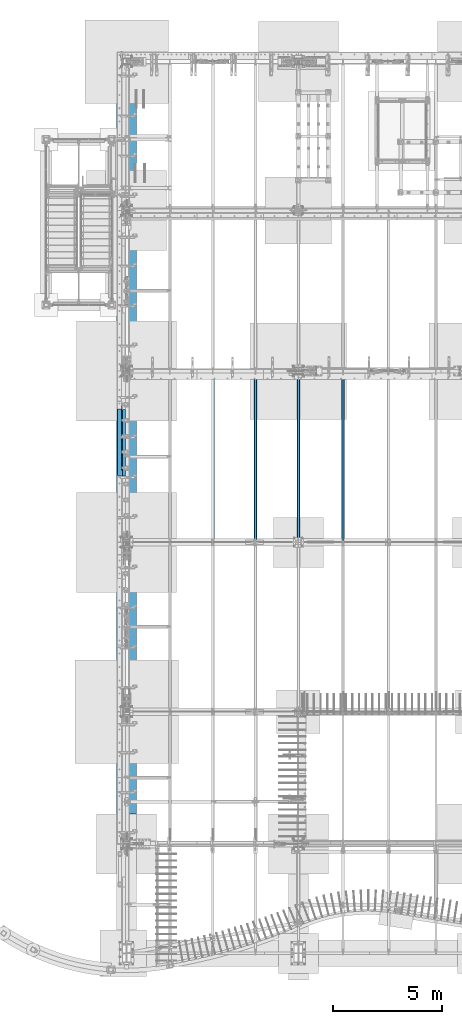
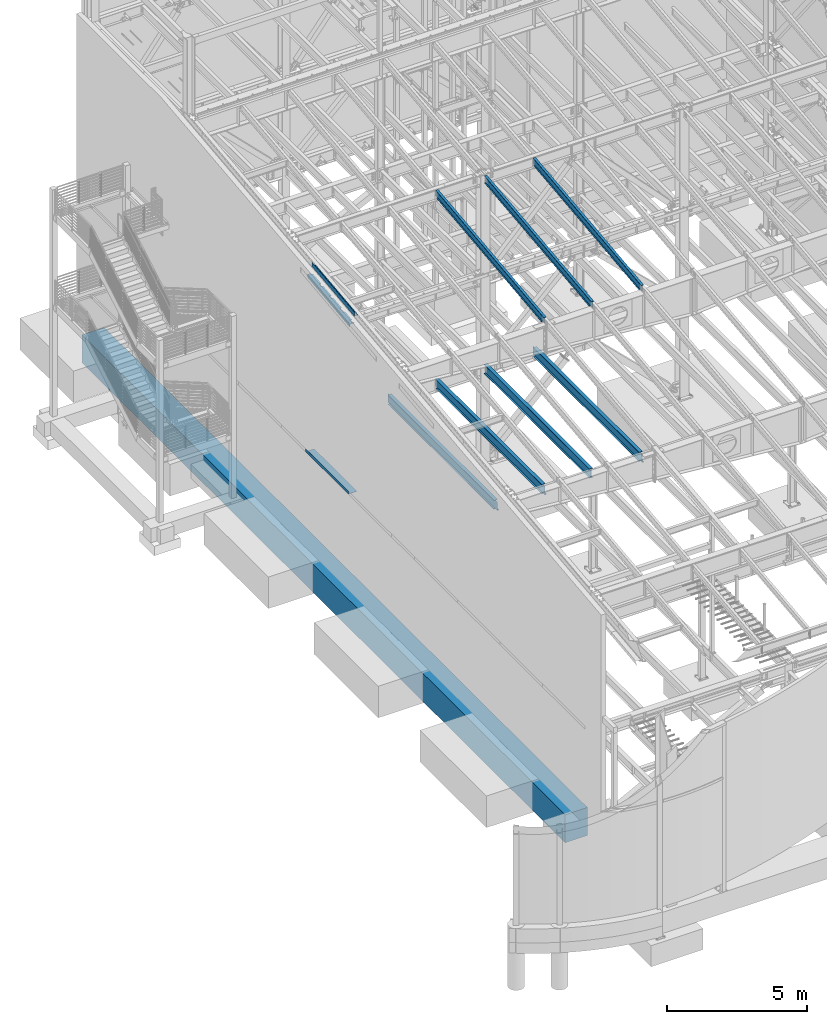
# One storey, part 727 of 1179: 11 beams, 10 elements without a shape of their own.
"""IFC2X3 building model written with IfcOpenShell, lengths in millimetres."""

from ifc_helpers import new_model, si_unit, frame, origin_with_axes, place, context, subcontext, project, spatial, faceted_brep, material, type_object, element, aggregate, save


model = new_model("IFC2X3")

# Units and contexts
model_context = context("Model", 3, precision=1e-05, world=origin_with_axes())
body_context = subcontext(model_context, "Body", "Model", "MODEL_VIEW")
ifc_project = project(units=[si_unit("LENGTHUNIT", "METRE", prefix="MILLI"), si_unit("AREAUNIT", "SQUARE_METRE"), si_unit("VOLUMEUNIT", "CUBIC_METRE"), si_unit("MASSUNIT", "GRAM", prefix="KILO"), si_unit("TIMEUNIT", "SECOND"), si_unit("PLANEANGLEUNIT", "RADIAN"), si_unit("SOLIDANGLEUNIT", "STERADIAN"), si_unit("THERMODYNAMICTEMPERATUREUNIT", "DEGREE_CELSIUS"), si_unit("LUMINOUSINTENSITYUNIT", "LUMEN")], contexts=[model_context])

# Site, building, storey
site_placement = place(None, origin_with_axes())
site = spatial("IfcSite", under=ifc_project, at=site_placement, CompositionType="ELEMENT")
building_placement = place(site_placement, origin_with_axes())
building = spatial("IfcBuilding", under=site, at=building_placement, Name="Undefined", CompositionType="ELEMENT")
storey_placement = place(building_placement, origin_with_axes())
storey = spatial("IfcBuildingStorey", under=building, at=storey_placement, Name="Undefined", CompositionType="ELEMENT", Elevation=0.0)

# Assembly, beam
assembly_1_placement = place(storey_placement, origin_with_axes())
assembly_1 = element("IfcElementAssembly", 1, at=assembly_1_placement, inside=storey, Name="BEAM", AssemblyPlace="NOTDEFINED", PredefinedType="RIGID_FRAME")
ifc_material_1 = material(Name="STEEL/A992")
beam_type_1 = type_object("IfcBeamType", Name="W16X31", PredefinedType="NOTDEFINED")
beam_1_placement = place(assembly_1_placement, frame((10325.1001686096, 19223.0375, 3900.4875), z_axis=(0.0, 0.0, 1.0), x_axis=(0.0, 1.0, 0.0)))
beam_1 = element("IfcBeam", 2, at=beam_1_placement, type_object=beam_type_1, material=ifc_material_1, Name="BEAM", ObjectType="W16X31", context=body_context, shape_type="Brep", body=[
    faceted_brep([(118.268749999999, -3.17499999999927, 169.862499809266), (118.268749999999, 3.17497767405257, 169.862499809266), (23.0187500000029, 3.17499999999927, 169.8625), (23.0187500000029, -3.17499999999927, 169.8625), (123.128829708781, -3.17499999999927, 170.829229922588), (123.128829708781, 3.17496867166847, 170.829229922588), (127.249006176935, -3.17499999999927, 173.582243823066), (127.249006176935, 3.17496689914333, 173.582243823066), (130.002020077412, -3.17499999999927, 177.70242029122), (130.002020077412, 3.17496424637102, 177.70242029122), (130.96875, -3.17499999999927, 182.562499809265), (130.96875, 3.17496111721084, 182.562499809265), (130.96875, -69.8500000000004, 201.6125), (130.96875, 69.8500000000004, 201.6125), (130.96875, 69.8500000000004, 190.5), (130.96875, 3.17499999999927, 190.5), (130.96875, -3.17499999999927, 190.5), (130.96875, -69.8500000000004, 190.5), (7651.75, 3.17499999999927, -190.5), (7651.75, 69.8500000000004, -190.5), (150.018750000003, 69.8500000000004, -190.5), (150.018749999999, 3.17549991607484, -190.5), (23.0187500000029, -3.17499999999927, -190.5), (23.0187500000029, -69.8500000000004, -190.5), (7807.325, -69.8500000000004, -190.5), (7807.325, -3.17499999999927, -190.5), (23.0187500000029, -69.8500000000004, -201.6125), (7807.325, -69.8500000000004, -201.6125), (7651.75, 69.8500000000004, -201.6125), (7651.75, 3.17549991607666, -201.6125), (7807.325, 3.17549991607666, -201.6125), (23.0187500000029, 3.17549991607484, -201.6125), (150.018749999999, 3.17549991607484, -201.6125), (150.018750000003, 69.8500000000004, -201.6125), (23.0187500000029, 3.17499999999927, -190.5), (7807.325, 3.17499999999927, -190.5), (7807.325, 3.17499999999927, 163.512499999999), (7807.325, -3.17499999999927, 163.512499999999), (7664.44999980926, 3.17499999999927, 163.512499999999), (7664.44999980926, -3.17499999999927, 163.512499999999), (7659.58992029121, 3.17499999999927, 164.479229922587), (7659.58992029121, -3.17499999999927, 164.479229922587), (7655.46974382306, 3.17499999999927, 167.232243823065), (7655.46974382306, -3.17499999999927, 167.232243823065), (7652.71672992258, 3.17499999999927, 171.352420291219), (7652.71672992258, -3.17499999999927, 171.352420291219), (7651.74999999999, 3.17499999999927, 176.212499809265), (7651.74999999999, -3.17499999999927, 176.212499809265), (7651.74999999999, -69.8500000000004, 201.6125), (7651.74999999999, -69.8500000000004, 190.5), (7651.74999999999, -3.17499999999927, 190.5), (7651.74999999999, 3.17499999999927, 190.5), (7651.74999999999, 69.8500000000004, 190.5), (7651.74999999999, 69.8500000000004, 201.6125)], [[[0, 1, 2, 3]], [[4, 5, 1, 0]], [[6, 7, 5, 4]], [[8, 9, 7, 6]], [[10, 11, 9, 8]], [[12, 13, 14, 15, 11, 10, 16, 17]], [[18, 19, 20, 21]], [[22, 23, 24, 25]], [[23, 26, 27, 24]], [[28, 29, 30, 27, 26, 31, 32, 33]], [[21, 32, 31, 34]], [[20, 33, 32, 21]], [[19, 28, 33, 20]], [[18, 29, 28, 19]], [[35, 30, 29, 18]], [[25, 24, 27, 30, 35, 36, 37]], [[37, 36, 38, 39]], [[39, 38, 40, 41]], [[41, 40, 42, 43]], [[43, 42, 44, 45]], [[45, 44, 46, 47]], [[48, 49, 50, 47, 46, 51, 52, 53]], [[49, 48, 12, 17]], [[50, 49, 17, 16]], [[8, 6, 4, 0, 3, 22, 25, 37, 39, 41, 43, 45, 47, 50, 16, 10]], [[34, 31, 26, 23, 22, 3, 2]], [[51, 46, 44, 42, 40, 38, 36, 35, 18, 21, 34, 2, 1, 5, 7, 9, 11, 15]], [[52, 51, 15, 14]], [[53, 52, 14, 13]], [[48, 53, 13, 12]]]),
])
aggregate(assembly_1, [beam_1])

assembly_2_placement = place(storey_placement, origin_with_axes())
assembly_2 = element("IfcElementAssembly", 3, at=assembly_2_placement, inside=storey, Name="BEAM", AssemblyPlace="NOTDEFINED", PredefinedType="RIGID_FRAME")
beam_2_placement = place(assembly_2_placement, frame((8280.4, 19227.8, 3900.4875), z_axis=(0.0, 0.0, 1.0), x_axis=(0.0, 1.0, 0.0)))
beam_2 = element("IfcBeam", 4, at=beam_2_placement, type_object=beam_type_1, material=ifc_material_1, Name="BEAM", ObjectType="W16X31", context=body_context, shape_type="Brep", body=[
    faceted_brep([(114.299999999999, -69.8500000000004, -201.6125), (114.299999999999, 69.8500000000004, -201.6125), (7627.9375, 69.8500000000004, -201.6125), (7627.9375, -69.8500000000004, -201.6125), (114.299999999999, -69.8500000000004, -190.5), (114.299999999999, -3.17499999999927, -190.5), (114.299999999999, -3.17499999999927, 190.5), (114.299999999999, -69.8500000000004, 190.5), (114.299999999999, -69.8500000000004, 201.6125), (114.299999999999, 69.8500000000004, 201.6125), (114.299999999999, 69.8500000000004, 190.5), (114.299999999999, 3.17499999999927, 190.5), (114.299999999999, 3.17499999999927, 164.25250072541), (114.299999999999, 3.17499999999927, -142.0275032968), (114.299999999999, 3.17499999999927, -190.5), (114.299999999999, 69.8500000000004, -190.5), (7627.9375, -69.8500000000004, -190.5), (7627.9375, -3.17499999999927, -190.5), (7627.9375, -3.17499999999927, 190.5), (7627.9375, -69.8500000000004, 190.5), (7627.9375, -69.8500000000004, 201.6125), (7627.9375, 69.8500000000004, 201.6125), (7627.9375, 69.8500000000004, 190.5), (7627.9375, 3.17499999999927, 190.5), (7627.9375, 3.17499999999927, -190.5), (7627.9375, 69.8500000000004, -190.5)], [[[0, 1, 2, 3]], [[0, 4, 5, 6, 7, 8, 9, 10, 11, 12, 13, 14, 15, 1]], [[5, 4, 16, 17]], [[6, 5, 17, 18]], [[7, 6, 18, 19]], [[8, 7, 19, 20]], [[9, 8, 20, 21]], [[10, 9, 21, 22]], [[11, 10, 22, 23]], [[14, 13, 12, 11, 23, 24]], [[15, 14, 24, 25]], [[1, 15, 25, 2]], [[24, 23, 22, 21, 20, 19, 18, 17, 16, 3, 2, 25]], [[4, 0, 3, 16]]]),
])
aggregate(assembly_2, [beam_2])

assembly_3_placement = place(storey_placement, origin_with_axes())
assembly_3 = element("IfcElementAssembly", 5, at=assembly_3_placement, inside=storey, Name="BEAM", AssemblyPlace="NOTDEFINED", PredefinedType="RIGID_FRAME")
beam_3_placement = place(assembly_3_placement, frame((6324.59996643066, 19223.0375, 3900.4875), z_axis=(0.0, 0.0, 1.0), x_axis=(0.0, 1.0, 0.0)))
beam_3 = element("IfcBeam", 6, at=beam_3_placement, type_object=beam_type_1, material=ifc_material_1, Name="BEAM", ObjectType="W16X31", context=body_context, shape_type="Brep", body=[
    faceted_brep([(118.268749999999, -3.17499999999927, 169.862499809266), (118.268749999999, 3.17497767405257, 169.862499809266), (23.0187500000029, 3.17499999999927, 169.8625), (23.0187500000029, -3.17499999999927, 169.8625), (123.128829708781, -3.17499999999927, 170.829229922588), (123.128829708781, 3.17496867166847, 170.829229922588), (127.249006176935, -3.17499999999927, 173.582243823066), (127.249006176935, 3.17496689914333, 173.582243823066), (130.002020077412, -3.17499999999927, 177.70242029122), (130.002020077412, 3.17496424637102, 177.70242029122), (130.96875, -3.17499999999927, 182.562499809265), (130.96875, 3.17496111721084, 182.562499809265), (130.96875, -69.8500000000004, 201.6125), (130.96875, 69.8500000000004, 201.6125), (130.96875, 69.8500000000004, 190.5), (130.96875, 3.17499999999927, 190.5), (130.96875, -3.17499999999927, 190.5), (130.96875, -69.8500000000004, 190.5), (7681.91250000001, 3.17500000000018, -190.5), (7681.91250000001, 69.8500000000004, -190.5), (150.018750000003, 69.8500000000004, -190.5), (150.018749999999, 3.17549991607484, -190.5), (23.0187500000029, -3.17499999999927, -190.5), (23.0187500000029, -69.8500000000004, -190.5), (7808.9125, -69.8500000000004, -190.5), (7808.9125, -3.17500000000018, -190.5), (23.0187500000029, -69.8500000000004, -201.6125), (7808.9125, -69.8500000000004, -201.6125), (7681.91250000001, 69.8500000000004, -201.6125), (7681.91250000001, 3.17549991607757, -201.6125), (7808.9125, 3.17549991607757, -201.6125), (23.0187500000029, 3.17549991607484, -201.6125), (150.018749999999, 3.17549991607484, -201.6125), (150.018750000003, 69.8500000000004, -201.6125), (23.0187500000029, 3.17499999999927, -190.5), (7808.9125, 3.17500000000018, -190.5), (7808.9125, 3.17500000000018, 169.8625), (7808.9125, -3.17500000000018, 169.8625), (7713.66249980926, 3.17500000000018, 169.8625), (7713.66249980926, -3.17500000000018, 169.8625), (7708.80242029121, 3.17500000000018, 170.829229922588), (7708.80242029121, -3.17500000000018, 170.829229922588), (7704.68224382306, 3.17500000000018, 173.582243823066), (7704.68224382306, -3.17500000000018, 173.582243823066), (7701.92922992258, 3.17500000000018, 177.70242029122), (7701.92922992258, -3.17500000000018, 177.70242029122), (7700.96249999999, 3.17500000000018, 182.562499809265), (7700.96249999999, -3.17500000000018, 182.562499809265), (7700.96249999999, -69.8500000000004, 201.6125), (7700.96249999999, -69.8500000000004, 190.5), (7700.96249999999, -3.17500000000018, 190.5), (7700.96249999999, 3.17500000000018, 190.5), (7700.96249999999, 69.8500000000004, 190.5), (7700.96249999999, 69.8500000000004, 201.6125)], [[[0, 1, 2, 3]], [[4, 5, 1, 0]], [[6, 7, 5, 4]], [[8, 9, 7, 6]], [[10, 11, 9, 8]], [[12, 13, 14, 15, 11, 10, 16, 17]], [[18, 19, 20, 21]], [[22, 23, 24, 25]], [[23, 26, 27, 24]], [[28, 29, 30, 27, 26, 31, 32, 33]], [[21, 32, 31, 34]], [[20, 33, 32, 21]], [[19, 28, 33, 20]], [[18, 29, 28, 19]], [[35, 30, 29, 18]], [[25, 24, 27, 30, 35, 36, 37]], [[37, 36, 38, 39]], [[39, 38, 40, 41]], [[41, 40, 42, 43]], [[43, 42, 44, 45]], [[45, 44, 46, 47]], [[48, 49, 50, 47, 46, 51, 52, 53]], [[49, 48, 12, 17]], [[50, 49, 17, 16]], [[8, 6, 4, 0, 3, 22, 25, 37, 39, 41, 43, 45, 47, 50, 16, 10]], [[34, 31, 26, 23, 22, 3, 2]], [[51, 46, 44, 42, 40, 38, 36, 35, 18, 21, 34, 2, 1, 5, 7, 9, 11, 15]], [[52, 51, 15, 14]], [[53, 52, 14, 13]], [[48, 53, 13, 12]]]),
])
aggregate(assembly_3, [beam_3])

assembly_4_placement = place(storey_placement, origin_with_axes())
assembly_4 = element("IfcElementAssembly", 7, at=assembly_4_placement, inside=storey, Name="BEAM", AssemblyPlace="NOTDEFINED", PredefinedType="RIGID_FRAME")
beam_4_placement = place(assembly_4_placement, frame((4368.8, 19227.8, 3900.4875), z_axis=(0.0, 0.0, 1.0), x_axis=(0.0, 1.0, 0.0)))
beam_4 = element("IfcBeam", 8, at=beam_4_placement, type_object=beam_type_1, material=ifc_material_1, Name="BEAM", ObjectType="W16X31", context=body_context, shape_type="Brep", body=[
    faceted_brep([(113.506251936145, -3.17499999997744, 169.8625), (113.506251936145, 3.17496422017757, 169.8625), (18.2562514952835, 3.17499999999927, 169.8625), (18.2562514952835, -3.17499999999927, 169.8625), (118.366331454192, -3.17499999997926, 170.829229922588), (118.366331454192, 3.17496349569046, 170.829229922588), (122.486507922345, -3.17499999997744, 173.582243823066), (122.486507922345, 3.17496143253265, 173.582243823066), (125.239521822827, -3.17499999997563, 177.70242029122), (125.239521822819, 3.17495834479632, 177.70242029122), (126.206251745411, -3.17499999997744, 182.562499809265), (126.206251745411, 3.1749547025629, 182.562499809265), (126.206251745432, -69.8499999999767, 201.6125), (126.206251745396, 69.850000000024, 201.6125), (126.206251745396, 69.850000000024, 190.5), (126.206251745418, 3.17500000002292, 190.5), (126.206251745411, -3.17499999997744, 190.5), (126.206251745432, -69.8499999999767, 190.5), (7677.15000000001, 3.17499999999927, -190.5), (7677.15000000001, 69.8499999999985, -190.5), (145.256250000001, 69.8499999999985, -190.5), (145.256250000001, 3.17549991607666, -190.5), (18.2562500000006, -3.17500000000291, -190.5), (18.2562500000006, -69.8499999999985, -190.5), (7804.15, -69.8499999999985, -190.5), (7804.15, -3.17499999999927, -190.5), (18.2562500000006, -69.8499999999985, -201.612499999999), (7804.15, -69.8499999999985, -201.6125), (7677.15000000001, 69.8499999999985, -201.6125), (7677.15000000001, 3.17549991607666, -201.6125), (7804.15, 3.17549991607666, -201.6125), (18.2562500000006, 3.17549991607666, -201.612499999999), (145.256250000001, 3.17549991607666, -201.612499999999), (145.256250000001, 69.8499999999985, -201.612499999999), (18.2562500000006, 3.17500000000291, -190.5), (7804.15, 3.17499999999927, -190.5), (7804.15, 3.17499999999927, 169.8625), (7804.15, -3.17499999999927, 169.8625), (7708.89999980925, 3.17499999999927, 169.8625), (7708.89999980925, -3.17499999999927, 169.8625), (7704.03992029121, 3.17499999999927, 170.829229922588), (7704.03992029121, -3.17499999999927, 170.829229922588), (7699.91974382305, 3.17499999999927, 173.582243823066), (7699.91974382305, -3.17499999999927, 173.582243823066), (7697.16672992258, 3.17499999999927, 177.70242029122), (7697.16672992258, -3.17499999999927, 177.70242029122), (7696.19999999999, 3.17499999999927, 182.562499809265), (7696.19999999999, -3.17499999999927, 182.562499809265), (7696.19999999999, -69.8499999999985, 201.6125), (7696.19999999999, -69.8499999999985, 190.5), (7696.19999999999, -3.17499999999927, 190.5), (7696.19999999999, 3.17499999999927, 190.5), (7696.19999999999, 69.8499999999985, 190.5), (7696.19999999999, 69.8499999999985, 201.6125)], [[[0, 1, 2, 3]], [[4, 5, 1, 0]], [[6, 7, 5, 4]], [[8, 9, 7, 6]], [[10, 11, 9, 8]], [[12, 13, 14, 15, 11, 10, 16, 17]], [[18, 19, 20, 21]], [[22, 23, 24, 25]], [[23, 26, 27, 24]], [[28, 29, 30, 27, 26, 31, 32, 33]], [[21, 32, 31, 34]], [[20, 33, 32, 21]], [[19, 28, 33, 20]], [[18, 29, 28, 19]], [[35, 30, 29, 18]], [[25, 24, 27, 30, 35, 36, 37]], [[37, 36, 38, 39]], [[39, 38, 40, 41]], [[41, 40, 42, 43]], [[43, 42, 44, 45]], [[45, 44, 46, 47]], [[48, 49, 50, 47, 46, 51, 52, 53]], [[49, 48, 12, 17]], [[50, 49, 17, 16]], [[8, 6, 4, 0, 3, 22, 25, 37, 39, 41, 43, 45, 47, 50, 16, 10]], [[34, 31, 26, 23, 22, 3, 2]], [[51, 46, 44, 42, 40, 38, 36, 35, 18, 21, 34, 2, 1, 5, 7, 9, 11, 15]], [[52, 51, 15, 14]], [[53, 52, 14, 13]], [[48, 53, 13, 12]]]),
])
aggregate(assembly_4, [beam_4])

# Assembly, beams
assembly_5_placement = place(storey_placement, origin_with_axes())
assembly_5 = element("IfcElementAssembly", 9, at=assembly_5_placement, inside=storey, Name="BEAM", AssemblyPlace="NOTDEFINED", PredefinedType="RIGID_FRAME")
ifc_material_2 = material(Name="STEEL/A36")
beam_type_2 = type_object("IfcBeamType", PredefinedType="NOTDEFINED")
beam_5_placement = place(assembly_5_placement, frame((388.937000000002, 23773.6008477538, 11936.4607052153), z_axis=(0.0, -0.993676146336441, -0.112284087038017), x_axis=(-1.0, 0.0, 0.0)))
beam_5 = element("IfcBeam", 10, at=beam_5_placement, type_object=beam_type_2, material=ifc_material_2, Name="BENT_PLATE", context=body_context, shape_type="Brep", body=[
    faceted_brep([(0.0, -3.17499999999927, -1524.0), (6.00266503170133e-10, -3.17499999922438, 1524.00000000052), (6.00266503170133e-10, 3.17500000077416, 1524.00000000052), (0.0, 3.17499999999927, -1524.0), (160.336999999976, 3.174999999379, 1523.99999999915), (160.33700000004, 3.17500000061409, -1523.99999999915), (153.98700000004, -3.17499999938263, -1523.99999999915), (153.986999999976, -3.17500000061773, 1523.99999999914), (160.337000000008, -187.325000000099, 1523.99999999907), (160.337000000008, -187.324999998866, -1523.99999999923), (153.987000000008, -187.325000000099, 1523.99999999907), (153.987000000008, -187.324999998866, -1523.99999999923)], [[[0, 1, 2, 3]], [[3, 2, 4, 5]], [[1, 0, 6, 7]], [[5, 4, 8, 9]], [[4, 2, 1, 7, 10, 8]], [[7, 6, 11, 10]], [[6, 0, 3, 5, 9, 11]], [[10, 11, 9, 8]]]),
])
beam_type_3 = type_object("IfcBeamType", PredefinedType="NOTDEFINED")
beam_6_placement = place(assembly_5_placement, frame((388.937000142327, 24031.5938429566, 11436.8075932375), z_axis=(0.0, -0.993676146336441, -0.112284087038017), x_axis=(-1.0, 0.0, 0.0)))
beam_6 = element("IfcBeam", 11, at=beam_6_placement, type_object=beam_type_3, material=ifc_material_2, Name="BENT_PLATE", context=body_context, shape_type="Brep", body=[
    faceted_brep([(76.199500142026, -3.26211877053356, -1456.45206731827), (76.199500142026, 3.08849484321763, -1456.45206732078), (76.1995001437463, 3.17499999937536, -1523.99999999915), (76.1995001437463, -3.17500000061955, -1523.99999999915), (2.27373675443232e-13, -3.1749999994081, -1456.45206731827), (-2.27373675443232e-13, 3.17500000058681, -1456.45206732078), (76.1995001419847, -3.26259153040701, -862.450614238907), (76.1995001419847, 3.08802208334419, -862.450614241465), (-2.27373675443232e-13, 3.17500000034488, -862.450614241465), (2.27373675443232e-13, -3.17499999965003, -862.450614238907), (76.1995001419847, -3.26211877082642, -725.925614255353), (76.1995001419847, 3.08849484292296, -725.925614257867), (2.27373675443232e-13, -3.1749999997046, -725.925614255353), (-2.27373675443232e-13, 3.17500000029213, -725.925614257863), (2.27373675443232e-13, -3.1749999999447, -131.924150492316), (-2.27373675443232e-13, 3.1750000000502, -131.924150494873), (76.1995001419434, -3.26259153070714, -131.924150492316), (76.1995001419434, 3.08802208304405, -131.924150494873), (76.1995001419434, -3.26211877112655, 4.60084949124212), (76.1995001419434, 3.08849484262464, 4.60084948872827), (2.27373675443232e-13, -3.17500000000109, 4.60084949123484), (-2.27373675443232e-13, 3.17499999999382, 4.60084948872463), (2.27373675443232e-13, -3.17500000024302, 604.952313234051), (-2.27373675443232e-13, 3.17499999975189, 604.952313236328), (76.1995001419022, -3.17500000024484, 604.952313234051), (76.1995001419022, 3.17561361350454, 604.952313236328), (76.1995001419022, -3.1745270570882, 836.235981337893), (76.1995001419022, 3.17608655665754, 836.235981340218), (2.27373675443232e-13, -3.1750000003376, 836.235981337897), (-2.27373675443232e-13, 3.1749999996573, 836.235981340214), (2.27373675443232e-13, -3.17500000053951, 1329.12877700083), (-2.27373675443232e-13, 3.17499999945903, 1329.12877699827), (76.1995001418609, -3.26259153129467, 1329.12877700083), (76.1995001418609, 3.08802208245834, 1329.12877699827), (76.1995001418609, -3.26211877171409, 1465.65377698438), (76.1995001418609, 3.08849484203711, 1465.65377698186), (2.27373675443232e-13, -3.17500000059408, 1465.65377698438), (-2.27373675443232e-13, 3.17499999940446, 1465.65377698187), (6.00266503170133e-10, -3.17499999922438, 1524.00000000052), (6.00266503170133e-10, 3.17500000077416, 1524.00000000052), (179.387000203274, 3.1749999978274, 1523.9999999998), (185.737000203274, -3.17500000222026, 1523.9999999998), (185.737000202948, 136.524999792873, 1523.99999999976), (179.387000202948, 136.524999792875, 1523.99999999976), (179.387000201926, 3.17499999921893, -1523.99999999987), (179.387000202255, 136.524999793486, -1523.99999999991), (185.737000202255, 136.524999793486, -1523.99999999991), (185.737000201926, -3.17500000083055, -1523.99999999987)], [[[0, 1, 2, 3]], [[4, 5, 1, 0]], [[6, 7, 8, 9]], [[10, 11, 7, 6]], [[12, 13, 11, 10]], [[14, 15, 13, 12]], [[16, 17, 15, 14]], [[18, 19, 17, 16]], [[20, 21, 19, 18]], [[22, 23, 21, 20]], [[24, 25, 23, 22]], [[26, 27, 25, 24]], [[28, 29, 27, 26]], [[30, 31, 29, 28]], [[32, 33, 31, 30]], [[34, 35, 33, 32]], [[36, 37, 35, 34]], [[38, 39, 37, 36]], [[40, 39, 38, 41, 42, 43]], [[44, 40, 43, 45]], [[42, 46, 45, 43]], [[41, 47, 46, 42]], [[44, 45, 46, 47, 3, 2]], [[8, 7, 11, 13, 15, 17, 19, 21, 23, 25, 27, 29, 31, 33, 35, 37, 39, 40, 44, 2, 1, 5]], [[9, 8, 5, 4]], [[47, 41, 38, 36, 34, 32, 30, 28, 26, 24, 22, 20, 18, 16, 14, 12, 10, 6, 9, 4, 0, 3]]]),
])
aggregate(assembly_5, [beam_6, beam_5])

# Assembly, beam
assembly_6_placement = place(storey_placement, origin_with_axes())
assembly_6 = element("IfcElementAssembly", 12, at=assembly_6_placement, inside=storey, Name="BEAM", AssemblyPlace="NOTDEFINED", PredefinedType="RIGID_FRAME")
beam_type_4 = type_object("IfcBeamType", PredefinedType="NOTDEFINED")
beam_7_placement = place(assembly_6_placement, frame((352.424987792969, 23802.975, 4105.275), z_axis=(0.0, -1.0, 0.0), x_axis=(-1.0, 0.0, 0.0)))
beam_7 = element("IfcBeam", 13, at=beam_7_placement, type_object=beam_type_4, material=ifc_material_2, Name="BENT_PLATE", context=body_context, shape_type="Brep", body=[
    faceted_brep([(0.0, -3.17499999999927, -1524.0), (6.00266503170133e-10, -3.17499999922438, 1524.00000000052), (6.00266503170133e-10, 3.17500000077416, 1524.00000000052), (0.0, 3.17499999999927, -1524.0), (352.424987792969, 3.17499999999927, 1524.0), (352.424987792969, 3.17499999999927, -1524.0), (346.074987792969, -3.17500000000109, -1524.0), (346.074987792969, -3.17500000000109, 1524.0), (352.424987792969, -130.175006103515, 1524.0), (352.424987792969, -130.175006103515, -1524.0), (346.074987792969, -130.175006103515, 1524.0), (346.074987792969, -130.175006103515, -1524.0)], [[[0, 1, 2, 3]], [[3, 2, 4, 5]], [[1, 0, 6, 7]], [[5, 4, 8, 9]], [[4, 2, 1, 7, 10, 8]], [[7, 6, 11, 10]], [[6, 0, 3, 5, 9, 11]], [[10, 11, 9, 8]]]),
])
aggregate(assembly_6, [beam_7])

assembly_7_placement = place(storey_placement, origin_with_axes())
assembly_7 = element("IfcElementAssembly", 14, at=assembly_7_placement, inside=storey, Name="BEAM", AssemblyPlace="NOTDEFINED", PredefinedType="RIGID_FRAME")
beam_type_5 = type_object("IfcBeamType", Name="W12X22", PredefinedType="NOTDEFINED")
beam_8_placement = place(assembly_7_placement, frame((10325.1, 19245.2779321397, 11265.0059190149), z_axis=(0.0, -0.112284087038017, 0.993676146336441), x_axis=(0.0, 0.993676146336441, 0.112284087038017)))
beam_8 = element("IfcBeam", 15, at=beam_8_placement, type_object=beam_type_5, material=ifc_material_1, Name="BEAM", ObjectType="W12X22", context=body_context, shape_type="Brep", body=[
    faceted_brep([(7676.8057846648, 3.17499999999927, -144.462500003032), (7676.80578466482, 3.17490308365814, -155.575000003026), (7676.80577856895, 50.7999999999993, -155.575000003026), (7676.80577856896, 50.7999999999993, -144.462500003034), (7820.7019525921, 3.17499999999927, -144.462500003092), (7819.44625482597, 3.17492134140048, -155.575000003084), (5.12531926095107, 3.17499999999927, 144.46249999992), (5.12531926095107, 50.7999999999993, 144.46249999992), (7757.4939140051, 50.7999999999993, 144.462499996773), (7757.4939140051, 3.17499999999927, 144.462499996773), (5.12531926095107, -3.17499999999927, 144.46249999992), (5.12531926095107, -50.7999999999993, 144.46249999992), (6.38101702707718, -50.7999999999993, 155.574999999912), (6.38101702707718, 50.7999999999993, 155.574999999912), (-25.0621566261689, 3.17499999999927, -122.686438896275), (-25.0621566261689, -3.17499999999927, -122.686438896275), (145.312894957096, 3.17499999999927, -141.93859400049), (145.312894957096, -3.17499999999927, -141.93859400049), (145.027696926005, -3.17499999999927, -144.462499999976), (145.027696926005, -50.7999999999993, -144.462499999976), (7676.805791578, -50.7999999999993, -144.462500003034), (7676.805785482, -3.17499999999927, -144.462500003032), (145.027696926005, 3.17499999999927, -144.462499999976), (145.027696926005, 50.7999999999993, -144.462499999976), (143.771999161854, 50.7999999999993, -155.574999999972), (143.771999161854, -50.7999999999993, -155.574999999972), (7676.805791578, -50.7999999999993, -155.575000003026), (7676.80578548203, -3.17509692720705, -155.575000003026), (7820.7019525921, -3.17499999999927, -144.462500003092), (7819.44625482597, -3.17507866903179, -155.575000003084), (7760.28182167741, -3.17499999999927, 99.3123538561285), (7756.49682025474, -3.17499999999927, 102.510588352729), (7754.22384626446, -3.17499999999927, 106.91382908024), (7753.80893939206, -3.17499999999927, 111.851722553385), (7757.4939140051, -3.17499999999927, 144.462499996773), (7821.50556176969, -3.17499999999927, -137.350830916108), (7847.03058449439, -3.17499999999927, 88.5369763886902), (7765.00261837702, -3.17499999999927, 97.8060278004923), (7757.4939140051, -50.7999999999993, 144.462499996773), (7758.74961177122, -50.7999999999993, 155.574999996767), (7758.74961177122, 50.7999999999993, 155.574999996767), (7753.80893939206, 3.17499999999927, 111.851722553385), (7754.22384626446, 3.17499999999927, 106.91382908024), (7756.49682025474, 3.17499999999927, 102.510588352729), (7760.28182167741, 3.17499999999927, 99.3123538561285), (7765.00261837702, 3.17499999999927, 97.8060278004923), (7847.03058449439, 3.17499999999927, 88.5369763886902), (7821.50554925474, 3.17499999999927, -137.350941669098)], [[[0, 1, 2, 3]], [[4, 5, 1, 0]], [[6, 7, 8, 9]], [[10, 11, 12, 13, 7, 6, 14, 15]], [[15, 14, 16, 17]], [[18, 19, 20, 21]], [[17, 16, 22, 23, 24, 25, 19, 18]], [[19, 25, 26, 20]], [[20, 26, 27, 21]], [[28, 21, 27, 29]], [[30, 31, 32, 33, 34, 10, 15, 17, 18, 21, 28, 35, 36, 37]], [[11, 10, 34, 38]], [[12, 11, 38, 39]], [[13, 12, 39, 40]], [[7, 13, 40, 8]], [[39, 38, 34, 33, 41, 9, 8, 40]], [[32, 42, 41, 33]], [[31, 43, 42, 32]], [[30, 44, 43, 31]], [[37, 45, 44, 30]], [[36, 46, 45, 37]], [[47, 4, 0, 22, 16, 14, 6, 9, 41, 42, 43, 44, 45, 46]], [[23, 22, 0, 3]], [[24, 23, 3, 2]], [[29, 27, 26, 25, 24, 2, 1, 5]], [[47, 46, 36, 35, 28, 29, 5, 4]]]),
])
aggregate(assembly_7, [beam_8])

assembly_8_placement = place(storey_placement, origin_with_axes())
assembly_8 = element("IfcElementAssembly", 16, at=assembly_8_placement, inside=storey, Name="BEAM", AssemblyPlace="NOTDEFINED", PredefinedType="RIGID_FRAME")
beam_9_placement = place(assembly_8_placement, frame((8280.4, 19245.2779321397, 11265.0059190149), z_axis=(0.0, -0.112284087038017, 0.993676146336441), x_axis=(0.0, 0.993676146336441, 0.112284087038017)))
beam_9 = element("IfcBeam", 17, at=beam_9_placement, type_object=beam_type_5, material=ifc_material_1, Name="BEAM", ObjectType="W12X22", context=body_context, shape_type="Brep", body=[
    faceted_brep([(6.38101702707718, -50.7999999999993, 155.574999999912), (5.12531926095107, -50.7999999999993, 144.46249999992), (7675.21735919066, -50.7999999999993, 144.462499996805), (7676.47305695679, -50.7999999999993, 155.574999996801), (6.38101702707718, 50.7999999999993, 155.574999999912), (7676.47305695679, 50.7999999999993, 155.574999996801), (5.12531926095107, 50.7999999999993, 144.46249999992), (7675.21735919066, 50.7999999999993, 144.462499996805), (5.12531926095107, 3.17499999999927, 144.46249999992), (7675.21735919066, 3.17499999999927, 144.462499996805), (5.12531926095107, -3.17499999999927, 144.46249999992), (-25.0621566261689, 3.17499999999927, -122.686438896275), (-25.0621566261689, -3.17499999999927, -122.686438896275), (7675.21735919066, -3.17499999999927, 144.462499996805), (7642.56921727134, 3.17499999999927, -144.462500003019), (7642.56921727134, -3.17499999999927, -144.462500003019), (7642.56921727134, -50.7999999999993, -144.462500003019), (7641.31351950521, -50.7999999999993, -155.575000003011), (7641.31351950521, 50.7999999999993, -155.575000003011), (7642.56921727134, 50.7999999999993, -144.462500003019), (145.027696926005, -50.7999999999993, -144.462499999976), (143.771999161854, -50.7999999999993, -155.574999999972), (143.771999161854, 50.7999999999993, -155.574999999972), (145.027696926005, 50.7999999999993, -144.462499999976), (145.027696926005, 3.17499999999927, -144.462499999976), (145.312894957096, 3.17499999999927, -141.93859400049), (145.312894957096, -3.17499999999927, -141.93859400049), (145.027696926005, -3.17499999999927, -144.462499999976)], [[[0, 1, 2, 3]], [[4, 0, 3, 5]], [[6, 4, 5, 7]], [[8, 6, 7, 9]], [[10, 1, 0, 4, 6, 8, 11, 12]], [[1, 10, 13, 2]], [[14, 9, 7, 5, 3, 2, 13, 15, 16, 17, 18, 19]], [[17, 16, 20, 21]], [[18, 17, 21, 22]], [[19, 18, 22, 23]], [[14, 19, 23, 24]], [[8, 9, 14, 24, 25, 11]], [[12, 11, 25, 26]], [[15, 13, 10, 12, 26, 27]], [[16, 15, 27, 20]], [[26, 25, 24, 23, 22, 21, 20, 27]]]),
])
aggregate(assembly_8, [beam_9])

assembly_9_placement = place(storey_placement, origin_with_axes())
assembly_9 = element("IfcElementAssembly", 18, at=assembly_9_placement, inside=storey, Name="BEAM", AssemblyPlace="NOTDEFINED", PredefinedType="RIGID_FRAME")
beam_10_placement = place(assembly_9_placement, frame((6324.6, 19245.2779321397, 11265.0059190149), z_axis=(0.0, -0.112284087038017, 0.993676146336441), x_axis=(0.0, 0.993676146336441, 0.112284087038017)))
beam_10 = element("IfcBeam", 19, at=beam_10_placement, type_object=beam_type_5, material=ifc_material_1, Name="BEAM", ObjectType="W12X22", context=body_context, shape_type="Brep", body=[
    faceted_brep([(7676.8057846648, 3.17499999999927, -144.462500003032), (7676.80578466482, 3.17490308365814, -155.575000003026), (7676.80577856895, 50.7999999999993, -155.575000003026), (7676.80577856896, 50.7999999999993, -144.462500003034), (7820.7019525921, 3.17499999999927, -144.462500003092), (7819.44625482597, 3.17492134140048, -155.575000003084), (5.12531926095107, 3.17499999999927, 144.46249999992), (5.12531926095107, 50.7999999999993, 144.46249999992), (7757.4939140051, 50.7999999999993, 144.462499996773), (7757.4939140051, 3.17499999999927, 144.462499996773), (5.12531926095107, -3.17499999999927, 144.46249999992), (5.12531926095107, -50.7999999999993, 144.46249999992), (6.38101702707718, -50.7999999999993, 155.574999999912), (6.38101702707718, 50.7999999999993, 155.574999999912), (-23.6361487119248, 3.17499999999927, -110.066751837681), (-23.6361487119248, -3.17499999999927, -110.066751837681), (140.429059546248, 3.17499999999927, -128.605903005757), (140.429059546248, -3.17499999999927, -128.605903005757), (145.149856241293, 3.17499999999927, -130.112229064427), (145.149856241293, -3.17499999999927, -130.112229064427), (148.934857659475, 3.17499999999927, -133.310463561033), (148.934857659475, -3.17499999999927, -133.310463561033), (151.207831646803, 3.17499999999927, -137.713704286212), (151.207831646803, -3.17499999999927, -137.713704286212), (151.622738518741, 3.17499999999927, -142.651597755959), (151.622738518741, -3.17499999999927, -142.651597755959), (151.418108966391, -3.17499999999927, -144.46249999998), (151.418108966391, -50.7999999999993, -144.46249999998), (7676.805791578, -50.7999999999993, -144.462500003034), (7676.805785482, -3.17499999999927, -144.462500003032), (151.418108966391, 3.17499999999927, -144.46249999998), (151.418108966391, 50.7999999999993, -144.46249999998), (150.1624112014, 50.7999999999993, -155.574999999972), (150.1624112014, -50.7999999999993, -155.574999999972), (7676.805791578, -50.7999999999993, -155.575000003026), (7676.80578548203, -3.17509692720705, -155.575000003026), (7820.7019525921, -3.17499999999927, -144.462500003092), (7819.44625482597, -3.17507866903179, -155.575000003084), (7760.28182167741, -3.17499999999927, 99.3123538561285), (7756.49682025474, -3.17499999999927, 102.510588352729), (7754.22384626446, -3.17499999999927, 106.91382908024), (7753.80893939206, -3.17499999999927, 111.851722553385), (7757.4939140051, -3.17499999999927, 144.462499996773), (7821.50556176969, -3.17499999999927, -137.350830916108), (7847.03058449439, -3.17499999999927, 88.5369763886902), (7765.00261837702, -3.17499999999927, 97.8060278004923), (7757.4939140051, -50.7999999999993, 144.462499996773), (7758.74961177122, -50.7999999999993, 155.574999996767), (7758.74961177122, 50.7999999999993, 155.574999996767), (7753.80893939206, 3.17499999999927, 111.851722553385), (7754.22384626446, 3.17499999999927, 106.91382908024), (7756.49682025474, 3.17499999999927, 102.510588352729), (7760.28182167741, 3.17499999999927, 99.3123538561285), (7765.00261837702, 3.17499999999927, 97.8060278004923), (7847.03058449439, 3.17499999999927, 88.5369763886902), (7821.50554925474, 3.17499999999927, -137.350941669098)], [[[0, 1, 2, 3]], [[4, 5, 1, 0]], [[6, 7, 8, 9]], [[10, 11, 12, 13, 7, 6, 14, 15]], [[15, 14, 16, 17]], [[17, 16, 18, 19]], [[19, 18, 20, 21]], [[21, 20, 22, 23]], [[23, 22, 24, 25]], [[26, 27, 28, 29]], [[25, 24, 30, 31, 32, 33, 27, 26]], [[27, 33, 34, 28]], [[28, 34, 35, 29]], [[36, 29, 35, 37]], [[38, 39, 40, 41, 42, 10, 15, 17, 19, 21, 23, 25, 26, 29, 36, 43, 44, 45]], [[11, 10, 42, 46]], [[12, 11, 46, 47]], [[13, 12, 47, 48]], [[7, 13, 48, 8]], [[47, 46, 42, 41, 49, 9, 8, 48]], [[40, 50, 49, 41]], [[39, 51, 50, 40]], [[38, 52, 51, 39]], [[45, 53, 52, 38]], [[44, 54, 53, 45]], [[55, 4, 0, 30, 24, 22, 20, 18, 16, 14, 6, 9, 49, 50, 51, 52, 53, 54]], [[31, 30, 0, 3]], [[32, 31, 3, 2]], [[37, 35, 34, 33, 32, 2, 1, 5]], [[55, 54, 44, 43, 36, 37, 5, 4]]]),
])
aggregate(assembly_9, [beam_10])

assembly_10_placement = place(storey_placement, origin_with_axes())
assembly_10 = element("IfcElementAssembly", 20, at=assembly_10_placement, inside=storey, Name="GRADE_BEAM", AssemblyPlace="NOTDEFINED", PredefinedType="REINFORCEMENT_UNIT")
ifc_material_3 = material(Name="CONCRETE/5000")
beam_type_6 = type_object("IfcBeamType", PredefinedType="NOTDEFINED")
beam_11_placement = place(assembly_10_placement, frame((431.800003440117, 6807.2, -1041.4), z_axis=(0.0, 0.0, 1.0), x_axis=(0.0, 1.0, 0.0)))
beam_11 = element("IfcBeam", 21, at=beam_11_placement, type_object=beam_type_6, material=ifc_material_3, Name="GRADE_BEAM", context=body_context, shape_type="Brep", body=[
    faceted_brep([(0.0, 457.2, -609.6), (0.0, 457.2, 609.6), (34391.6, 457.2, 609.6), (34391.6, 457.2, -609.6), (0.0, -457.2, 609.6), (34391.6, -457.2, 609.6), (0.0, -457.2, -609.6), (34391.6, -457.2, -609.6)], [[[0, 1, 2, 3]], [[1, 4, 5, 2]], [[4, 6, 7, 5]], [[6, 0, 3, 7]], [[5, 7, 3, 2]], [[6, 4, 1, 0]]]),
])
aggregate(assembly_10, [beam_11])

save(model, "model.ifc")
